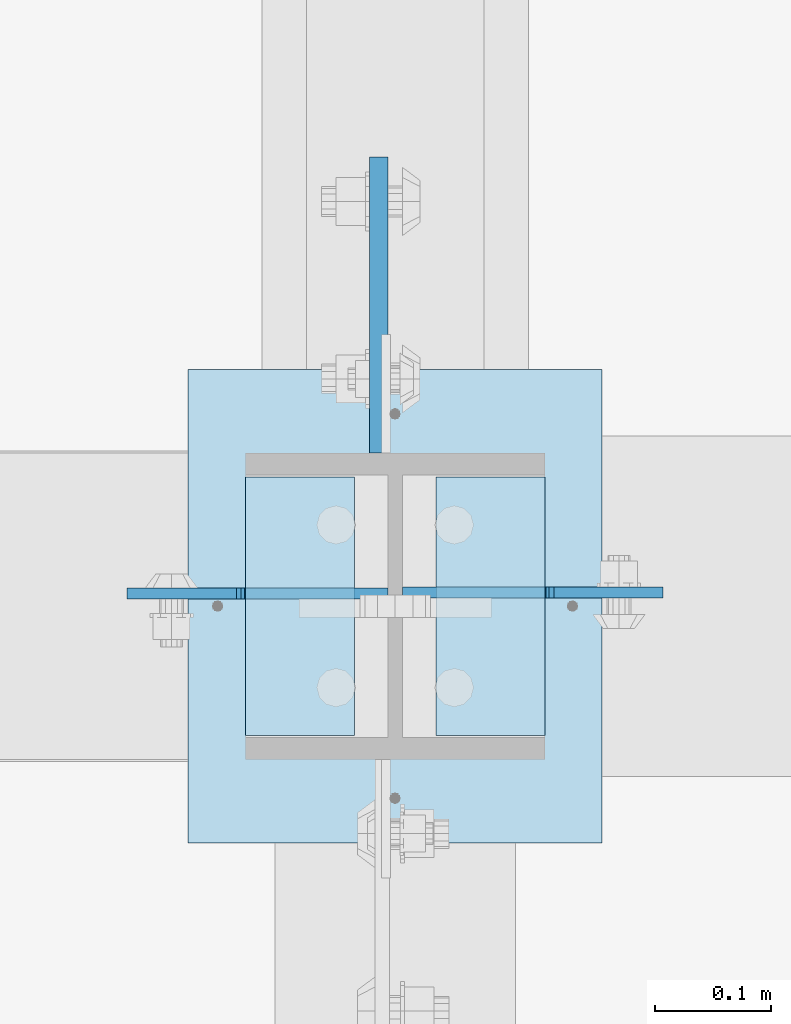
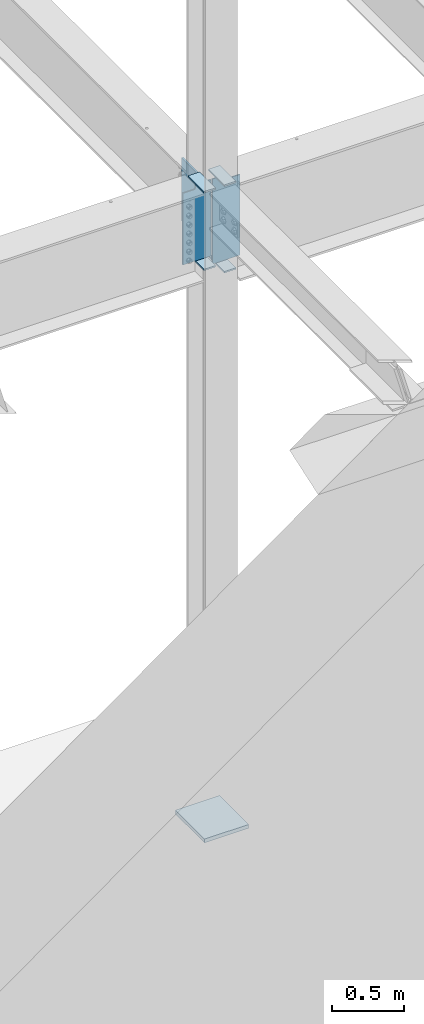
# One storey, part 1549 of 1763: 8 plates, 1 element without a shape of its own.
"""IFC2X3 building model written with IfcOpenShell, lengths in millimetres."""

from ifc_helpers import new_model, si_unit, frame, origin_with_axes, place, context, subcontext, project, spatial, faceted_brep, material, type_object, element, aggregate, save


model = new_model("IFC2X3")

# Units and contexts
model_context = context("Model", 3, precision=1e-05, world=origin_with_axes())
body_context = subcontext(model_context, "Body", "Model", "MODEL_VIEW")
ifc_project = project(units=[si_unit("LENGTHUNIT", "METRE", prefix="MILLI"), si_unit("AREAUNIT", "SQUARE_METRE"), si_unit("VOLUMEUNIT", "CUBIC_METRE"), si_unit("MASSUNIT", "GRAM", prefix="KILO"), si_unit("TIMEUNIT", "SECOND"), si_unit("PLANEANGLEUNIT", "RADIAN"), si_unit("SOLIDANGLEUNIT", "STERADIAN"), si_unit("THERMODYNAMICTEMPERATUREUNIT", "DEGREE_CELSIUS"), si_unit("LUMINOUSINTENSITYUNIT", "LUMEN")], contexts=[model_context])

# Site, building, storey
site_placement = place(None, origin_with_axes())
site = spatial("IfcSite", under=ifc_project, at=site_placement, CompositionType="ELEMENT")
building_placement = place(site_placement, origin_with_axes())
building = spatial("IfcBuilding", under=site, at=building_placement, Name="Undefined", CompositionType="ELEMENT")
storey_placement = place(building_placement, origin_with_axes())
storey = spatial("IfcBuildingStorey", under=building, at=storey_placement, Name="Undefined", CompositionType="ELEMENT", Elevation=0.0)

# Assembly, plates
assembly_placement = place(storey_placement, origin_with_axes())
assembly = element("IfcElementAssembly", 1, at=assembly_placement, inside=storey, Name="COLUMN", AssemblyPlace="NOTDEFINED", PredefinedType="RIGID_FRAME")
ifc_material_1 = material(Name="STEEL/A36")
plate_type_1 = type_object("IfcPlateType", PredefinedType="NOTDEFINED")
plate_1_placement = place(assembly_placement, frame((-49273.8497736983, 29911.675, 4451.34997558594), z_axis=(0.0, 1.0, 0.0), x_axis=(-1.0, 0.0, 0.0)))
plate_1 = element("IfcPlate", 2, at=plate_1_placement, type_object=plate_type_1, material=ifc_material_1, Name="PLATE", context=body_context, shape_type="Brep", body=[
    faceted_brep([(0.0, -6.34999999999491, 1.45519152283669e-11), (0.0, -6.35000000000036, 222.25), (0.0, 6.35000000000036, 222.25), (0.0, 6.34999999999491, -2.91038304567337e-11), (93.6624984741211, -6.35000000000036, 222.25), (93.6624984741211, 6.35000000000036, 222.25), (93.6624984741211, -6.35000000000036, 0.0), (93.6624984741211, 6.35000000000036, 0.0)], [[[0, 1, 2, 3]], [[1, 4, 5, 2]], [[4, 6, 7, 5]], [[6, 0, 3, 7]], [[5, 7, 3, 2]], [[6, 4, 1, 0]]]),
])
plate_2_placement = place(assembly_placement, frame((-49273.8497736983, 29911.675, 5187.95), z_axis=(0.0, 1.0, 0.0), x_axis=(-1.0, 0.0, 0.0)))
plate_2 = element("IfcPlate", 3, at=plate_2_placement, type_object=plate_type_1, material=ifc_material_1, Name="PLATE", context=body_context, shape_type="Brep", body=[
    faceted_brep([(0.0, -6.34999999999491, 1.45519152283669e-11), (0.0, -6.35000000000036, 222.25), (0.0, 6.35000000000036, 222.25), (0.0, 6.34999999999491, -2.91038304567337e-11), (93.6624984741211, -6.35000000000036, 222.25), (93.6624984741211, 6.35000000000036, 222.25), (93.6624984741211, -6.35000000000036, 0.0), (93.6624984741211, 6.35000000000036, 0.0)], [[[0, 1, 2, 3]], [[1, 4, 5, 2]], [[4, 6, 7, 5]], [[6, 0, 3, 7]], [[5, 7, 3, 2]], [[6, 4, 1, 0]]]),
])
plate_3_placement = place(assembly_placement, frame((-49531.0247736984, 30133.925, 4527.54998779297), z_axis=(0.0, -1.0, 0.0), x_axis=(1.0, 0.0, 0.0)))
plate_3 = element("IfcPlate", 4, at=plate_3_placement, type_object=plate_type_1, material=ifc_material_1, Name="PLATE", context=body_context, shape_type="Brep", body=[
    faceted_brep([(0.0, -6.34999999999491, 1.45519152283669e-11), (0.0, -6.35000000000036, 222.25), (0.0, 6.35000000000036, 222.25), (0.0, 6.34999999999491, -2.91038304567337e-11), (93.6624984741211, -6.35000000000036, 222.25), (93.6624984741211, 6.35000000000036, 222.25), (93.6624984741211, -6.35000000000036, 0.0), (93.6624984741211, 6.35000000000036, 0.0)], [[[0, 1, 2, 3]], [[1, 4, 5, 2]], [[4, 6, 7, 5]], [[6, 0, 3, 7]], [[5, 7, 3, 2]], [[6, 4, 1, 0]]]),
])
plate_4_placement = place(assembly_placement, frame((-49531.0247736984, 30133.925, 5187.95), z_axis=(0.0, -1.0, 0.0), x_axis=(1.0, 0.0, 0.0)))
plate_4 = element("IfcPlate", 5, at=plate_4_placement, type_object=plate_type_1, material=ifc_material_1, Name="PLATE", context=body_context, shape_type="Brep", body=[
    faceted_brep([(0.0, -6.34999999999491, 1.45519152283669e-11), (0.0, -6.35000000000036, 222.25), (0.0, 6.35000000000036, 222.25), (0.0, 6.34999999999491, -2.91038304567337e-11), (93.6624984741211, -6.35000000000036, 222.25), (93.6624984741211, 6.35000000000036, 222.25), (93.6624984741211, -6.35000000000036, 0.0), (93.6624984741211, 6.35000000000036, 0.0)], [[[0, 1, 2, 3]], [[1, 4, 5, 2]], [[4, 6, 7, 5]], [[6, 0, 3, 7]], [[5, 7, 3, 2]], [[6, 4, 1, 0]]]),
])
ifc_material_2 = material(Name="STEEL/A572-50")
plate_type_2 = type_object("IfcPlateType", PredefinedType="NOTDEFINED")
plate_5_placement = place(assembly_placement, frame((-49416.7247736983, 30154.5625, 5143.5), z_axis=(0.0, 1.0, 0.0), x_axis=(0.0, 0.0, -1.0)))
plate_5 = element("IfcPlate", 6, at=plate_5_placement, type_object=plate_type_2, material=ifc_material_2, Name="PLATE", context=body_context, shape_type="Brep", body=[
    faceted_brep([(-7.27595761418343e-12, -7.9375, 0.0), (0.0, -7.9375, 254.0), (0.0, 7.9375, 254.0), (-7.27595761418343e-12, 7.9375, 0.0), (533.400024414062, -7.9375, 254.0), (533.400024414062, 7.9375, 254.0), (533.400024414062, -7.9375, 0.0), (533.400024414062, 7.9375, 0.0)], [[[0, 1, 2, 3]], [[1, 4, 5, 2]], [[4, 6, 7, 5]], [[6, 0, 3, 7]], [[5, 7, 3, 2]], [[6, 4, 1, 0]]]),
])
plate_type_3 = type_object("IfcPlateType", PredefinedType="NOTDEFINED")
plate_6_placement = place(assembly_placement, frame((-49396.0872736984, 30034.70625, 5181.6), z_axis=(1.0, 0.0, 0.0), x_axis=(0.0, 0.0, -1.0)))
plate_6 = element("IfcPlate", 7, at=plate_6_placement, type_object=plate_type_3, material=ifc_material_1, Name="PLATE", context=body_context, shape_type="Brep", body=[
    faceted_brep([(25.4000001907334, -4.76250000000073, 122.237503051758), (25.4000001907334, 4.76250000000073, 122.237503051758), (-2.5465851649642e-11, 4.76250000019581, 122.237500000236), (-3.45607986673713e-11, -4.76249999983202, 122.23750000025), (30.2600797087798, -4.76250000000073, 123.204232974349), (30.2600797087798, 4.76250000000073, 123.204232974349), (34.3802561769335, -4.76250000000073, 125.957246874823), (34.3802561769335, 4.76250000000073, 125.957246874823), (37.133270077411, -4.76250000000073, 130.077423342977), (37.133270077411, 4.76250000000073, 130.077423342977), (38.0999999999985, -4.76250000000073, 134.937502861023), (38.0999999999985, 4.76250000000073, 134.937502861023), (38.0999999999985, -4.76250000000073, 223.837493896484), (38.0999999999985, 4.76250000000073, 223.837493896484), (723.900024414062, -4.76250000000073, 0.0), (0.0, -4.76249999999982, 0.0), (0.0, 4.76249999999982, 0.0), (723.900024414062, 4.76250000000073, 0.0), (723.900024414062, -4.76250000000073, 223.837493896484), (723.900024414062, 4.76250000000073, 223.837493896484)], [[[0, 1, 2, 3]], [[4, 5, 1, 0]], [[6, 7, 5, 4]], [[8, 9, 7, 6]], [[10, 11, 9, 8]], [[12, 13, 11, 10]], [[14, 15, 16, 17]], [[18, 14, 17, 19]], [[8, 6, 4, 0, 3, 15, 14, 18, 12, 10]], [[16, 15, 3, 2]], [[19, 17, 16, 2, 1, 5, 7, 9, 11, 13]], [[18, 19, 13, 12]]]),
])
plate_7_placement = place(assembly_placement, frame((-49408.7872736983, 30033.9125, 5181.6), z_axis=(-1.0, 0.0, 0.0), x_axis=(0.0, 0.0, -1.0)))
plate_7 = element("IfcPlate", 8, at=plate_7_placement, type_object=plate_type_3, material=ifc_material_1, Name="PLATE", context=body_context, shape_type="Brep", body=[
    faceted_brep([(25.4000001907334, -4.76250000000073, 122.237503051758), (25.4000001907334, 4.76250000000073, 122.237503051758), (-2.5465851649642e-11, 4.76250000019581, 122.237500000236), (-3.45607986673713e-11, -4.76249999983202, 122.23750000025), (30.2600797087798, -4.76250000000073, 123.204232974349), (30.2600797087798, 4.76250000000073, 123.204232974349), (34.3802561769335, -4.76250000000073, 125.957246874823), (34.3802561769335, 4.76250000000073, 125.957246874823), (37.133270077411, -4.76250000000073, 130.077423342977), (37.133270077411, 4.76250000000073, 130.077423342977), (38.0999999999985, -4.76250000000073, 134.937502861023), (38.0999999999985, 4.76250000000073, 134.937502861023), (38.0999999999985, -4.76250000000073, 223.837493896484), (38.0999999999985, 4.76250000000073, 223.837493896484), (647.700012207031, -4.76250000000073, 0.0), (0.0, -4.76249999999982, 0.0), (0.0, 4.76249999999982, 0.0), (647.700012207031, 4.76250000000073, 0.0), (647.700012207031, -4.76250000000073, 223.837493896484), (647.700012207031, 4.76250000000073, 223.837493896484)], [[[0, 1, 2, 3]], [[4, 5, 1, 0]], [[6, 7, 5, 4]], [[8, 9, 7, 6]], [[10, 11, 9, 8]], [[12, 13, 11, 10]], [[14, 15, 16, 17]], [[18, 14, 17, 19]], [[8, 6, 4, 0, 3, 15, 14, 18, 12, 10]], [[16, 15, 3, 2]], [[19, 17, 16, 2, 1, 5, 7, 9, 11, 13]], [[18, 19, 13, 12]]]),
])
plate_type_4 = type_object("IfcPlateType", PredefinedType="NOTDEFINED")
plate_8_placement = place(assembly_placement, frame((-49580.2372736984, 30226.0, -250.824999999999), z_axis=(1.0, 0.0, 0.0), x_axis=(0.0, -1.0, 0.0)))
plate_8 = element("IfcPlate", 9, at=plate_8_placement, type_object=plate_type_4, material=ifc_material_1, Name="PLATE", context=body_context, shape_type="Brep", body=[
    faceted_brep([(0.0, -15.875, 0.0), (0.0, -15.875, 355.600006103516), (0.0, 15.875, 355.600006103516), (0.0, 15.875, 0.0), (406.399993896484, -15.875, 355.600006103516), (406.399993896484, 15.875, 355.600006103516), (406.399993896484, -15.875, 0.0), (406.399993896484, 15.875, 0.0)], [[[0, 1, 2, 3]], [[1, 4, 5, 2]], [[4, 6, 7, 5]], [[6, 0, 3, 7]], [[5, 7, 3, 2]], [[6, 4, 1, 0]]]),
])
aggregate(assembly, [plate_1, plate_2, plate_6, plate_3, plate_4, plate_7, plate_5, plate_8])

save(model, "model.ifc")
